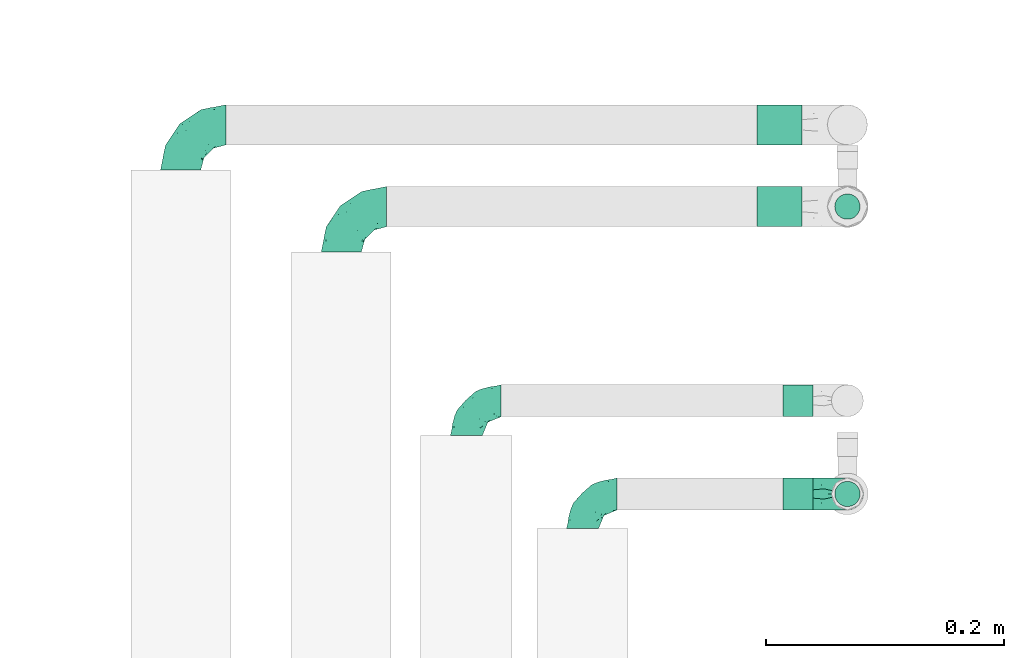
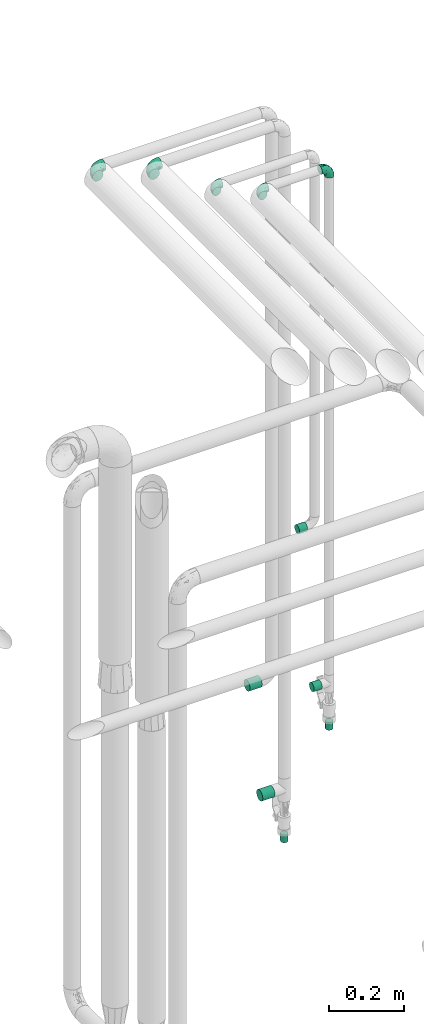
# One storey, part 746 of 827: 11 flow fittings.
"""IFC2X3 building model written with IfcOpenShell, lengths in millimetres."""

from ifc_helpers import new_model, entity, si_unit, converted_unit, derived_unit, direction, frame, origin, origin_2d_with_axis, place, context, subcontext, project, spatial, circle, extrude, faceted_brep, source, transform, mapped, material, type_object, type_shapes, element, save


model = new_model("IFC2X3")

# Units and contexts
model_context = context("Model", 3, precision=0.01, world=origin(), true_north=direction((6.12303176911189e-17, 1.0)))
body_context = subcontext(model_context, "Body", "Model", "MODEL_VIEW")
ifc_project = project(units=[si_unit("LENGTHUNIT", "METRE", prefix="MILLI"), si_unit("AREAUNIT", "SQUARE_METRE"), si_unit("VOLUMEUNIT", "CUBIC_METRE"), converted_unit("PLANEANGLEUNIT", "DEGREE", entity("IfcRatioMeasure", 0.0174532925199433), si_unit("PLANEANGLEUNIT", "RADIAN"), dimensions=[0, 0, 0, 0, 0, 0, 0]), si_unit("MASSUNIT", "GRAM", prefix="KILO"), derived_unit("MASSDENSITYUNIT", [(si_unit("MASSUNIT", "GRAM", prefix="KILO"), 1), (si_unit("LENGTHUNIT", "METRE"), -3)]), derived_unit("MOMENTOFINERTIAUNIT", [(si_unit("LENGTHUNIT", "METRE"), 4)]), si_unit("TIMEUNIT", "SECOND"), si_unit("FREQUENCYUNIT", "HERTZ"), si_unit("THERMODYNAMICTEMPERATUREUNIT", "DEGREE_CELSIUS"), derived_unit("THERMALTRANSMITTANCEUNIT", [(si_unit("MASSUNIT", "GRAM", prefix="KILO"), 1), (si_unit("THERMODYNAMICTEMPERATUREUNIT", "KELVIN"), -1), (si_unit("TIMEUNIT", "SECOND"), -3)]), derived_unit("VOLUMETRICFLOWRATEUNIT", [(si_unit("LENGTHUNIT", "METRE"), 3), (si_unit("TIMEUNIT", "SECOND"), -1)]), derived_unit("MASSFLOWRATEUNIT", [(si_unit("MASSUNIT", "GRAM", prefix="KILO"), 1), (si_unit("TIMEUNIT", "SECOND"), -1)]), derived_unit("ROTATIONALFREQUENCYUNIT", [(si_unit("TIMEUNIT", "SECOND"), -1)]), si_unit("ELECTRICCURRENTUNIT", "AMPERE"), si_unit("ELECTRICVOLTAGEUNIT", "VOLT"), si_unit("POWERUNIT", "WATT"), si_unit("FORCEUNIT", "NEWTON", prefix="KILO"), si_unit("ILLUMINANCEUNIT", "LUX"), si_unit("LUMINOUSFLUXUNIT", "LUMEN"), si_unit("LUMINOUSINTENSITYUNIT", "CANDELA"), derived_unit("USERDEFINED", [(si_unit("MASSUNIT", "GRAM", prefix="KILO"), -1), (si_unit("LENGTHUNIT", "METRE"), -2), (si_unit("TIMEUNIT", "SECOND"), 3), (si_unit("LUMINOUSFLUXUNIT", "LUMEN"), 1)]), derived_unit("LINEARVELOCITYUNIT", [(si_unit("LENGTHUNIT", "METRE"), 1), (si_unit("TIMEUNIT", "SECOND"), -1)]), si_unit("PRESSUREUNIT", "PASCAL"), derived_unit("USERDEFINED", [(si_unit("LENGTHUNIT", "METRE"), -2), (si_unit("MASSUNIT", "GRAM", prefix="KILO"), 1), (si_unit("TIMEUNIT", "SECOND"), -2)]), derived_unit("LINEARFORCEUNIT", [(si_unit("MASSUNIT", "GRAM", prefix="KILO"), 1), (si_unit("LENGTHUNIT", "METRE"), 1), (si_unit("TIMEUNIT", "SECOND"), -2), (si_unit("LENGTHUNIT", "METRE"), -1)]), derived_unit("PLANARFORCEUNIT", [(si_unit("MASSUNIT", "GRAM", prefix="KILO"), 1), (si_unit("LENGTHUNIT", "METRE"), 1), (si_unit("TIMEUNIT", "SECOND"), -2), (si_unit("LENGTHUNIT", "METRE"), -2)])], contexts=[model_context])

# Site, building, storey
site_placement = place(None, origin())
site = spatial("IfcSite", under=ifc_project, at=site_placement, CompositionType="ELEMENT")
building_placement = place(site_placement, origin())
building = spatial("IfcBuilding", under=site, at=building_placement, CompositionType="ELEMENT")
storey_placement = place(building_placement, frame((0.0, 0.0, 28200.0)))
storey = spatial("IfcBuildingStorey", under=building, at=storey_placement, Name="08", CompositionType="ELEMENT", Elevation=28200.0)

# Flow fittings
ifc_material = material()
pipe_fitting_type_1 = type_object("IfcPipeFittingType", PredefinedType="NOTDEFINED", material=ifc_material)
shared_shape_1 = source(origin(), body_context, "Body", "SweptSolid", [
    extrude(circle(Radius=16.85, at=origin_2d_with_axis()), frame((0.0, 0.0, 0.0), z_axis=(1.0, 0.0, 0.0), x_axis=(0.0, 1.0, 0.0)), (0.0, 0.0, 1.0), 38.0000000000003),
])
type_shapes(pipe_fitting_type_1, [shared_shape_1])
for number, where, z_axis, x_axis in (
    (1, (18867.55, 16586.6, 738.03), (0.0, 1.0, 0.0), (-1.0, 0.0, 0.0)),
    (2, (18867.55, 16517.91, 419.5), (0.0, 1.0, 0.0), (-1.0, 0.0, 0.0)),
):
    element("IfcFlowFitting", number, at=place(storey_placement, frame(where, z_axis=z_axis, x_axis=x_axis)), inside=storey, type_object=pipe_fitting_type_1, material=ifc_material, context=body_context, shape_type="MappedRepresentation", body=[
        mapped(shared_shape_1, transform((0.0, 0.0, 0.0), scale=1.0)),
    ])
pipe_fitting_type_2 = type_object("IfcPipeFittingType", PredefinedType="NOTDEFINED", material=ifc_material)
shared_shape_2 = source(origin(), body_context, "Body", "SweptSolid", [
    extrude(circle(Radius=10.65, at=origin_2d_with_axis()), frame((0.0, 0.0, 0.0), z_axis=(1.0, 0.0, 0.0), x_axis=(0.0, 1.0, 0.0)), (0.0, 0.0, 1.0), 25.0000000000003),
])
type_shapes(pipe_fitting_type_2, [shared_shape_2])
for number, where, z_axis, x_axis in (
    (3, (18905.55, 16517.91, 269.5), (0.0, 1.0, 0.0), (0.0, 0.0, -1.0)),
    (4, (18905.55, 16276.57, 784.61), (0.0, 1.0, 0.0), (0.0, 0.0, -1.0)),
):
    element("IfcFlowFitting", number, at=place(storey_placement, frame(where, z_axis=z_axis, x_axis=x_axis)), inside=storey, type_object=pipe_fitting_type_2, material=ifc_material, context=body_context, shape_type="MappedRepresentation", body=[
        mapped(shared_shape_2, transform((0.0, 0.0, 0.0), scale=1.0)),
    ])
pipe_fitting_type_3 = type_object("IfcPipeFittingType", PredefinedType="NOTDEFINED", material=ifc_material)
shared_shape_3 = source(origin(), body_context, "Body", "SweptSolid", [
    extrude(circle(Radius=13.45, at=origin_2d_with_axis()), frame((0.0, 0.0, 0.0), z_axis=(1.0, 0.0, 0.0), x_axis=(0.0, 1.0, 0.0)), (0.0, 0.0, 1.0), 25.0000000000003),
])
type_shapes(pipe_fitting_type_3, [shared_shape_3])
for number, where, z_axis, x_axis in (
    (5, (18876.45, 16354.91, 1382.4), (0.0, 1.0, 0.0), (-1.0, 0.0, 0.0)),
    (6, (18876.55, 16276.57, 912.61), (0.0, 1.0, 0.0), (-1.0, 0.0, 0.0)),
):
    element("IfcFlowFitting", number, at=place(storey_placement, frame(where, z_axis=z_axis, x_axis=x_axis)), inside=storey, type_object=pipe_fitting_type_3, material=ifc_material, context=body_context, shape_type="MappedRepresentation", body=[
        mapped(shared_shape_3, transform((0.0, 0.0, 0.0), scale=1.0)),
    ])
pipe_fitting_type_4 = type_object("IfcPipeFittingType", Name="ADSK_1", PredefinedType="NOTDEFINED", material=ifc_material)
shared_shape_4 = source(origin(), body_context, "Body", "Brep", [
    faceted_brep([(-38.0, 0.0, -16.85), (-38.0, -4.36, -16.28), (-38.0, -8.43, -14.59), (-38.0, -11.91, -11.91), (-38.0, -14.59, -8.43), (-38.0, -16.28, -4.36), (-38.0, -16.85, 0.0), (-38.0, -16.28, 4.36), (-38.0, -14.59, 8.42), (-38.0, -11.91, 11.91), (-38.0, -8.43, 14.59), (-38.0, -4.36, 16.28), (-38.0, 0.0, 16.85), (-38.0, 4.36, 16.28), (-38.0, 8.42, 14.59), (-38.0, 11.91, 11.91), (-38.0, 14.59, 8.42), (-38.0, 16.28, 4.36), (-38.0, 16.85, 0.0), (-38.0, 16.28, -4.36), (-38.0, 14.59, -8.43), (-38.0, 11.91, -11.91), (-38.0, 8.42, -14.59), (-38.0, 4.36, -16.28), (-4.36, 38.0, -16.28), (-8.42, 38.0, -14.59), (-11.91, 38.0, -11.91), (-14.59, 38.0, -8.43), (-16.28, 38.0, -4.36), (-16.85, 38.0, 0.0), (-16.28, 38.0, 4.36), (-14.59, 38.0, 8.42), (-11.91, 38.0, 11.91), (-8.42, 38.0, 14.59), (-4.36, 38.0, 16.28), (0.0, 38.0, 16.85), (4.36, 38.0, 16.28), (8.43, 38.0, 14.59), (11.91, 38.0, 11.91), (14.59, 38.0, 8.42), (16.28, 38.0, 4.36), (16.85, 38.0, 0.0), (16.28, 38.0, -4.36), (14.59, 38.0, -8.43), (11.91, 38.0, -11.91), (8.43, 38.0, -14.59), (4.36, 38.0, -16.28), (0.0, 38.0, -16.85), (-27.9, -12.9, 9.54), (-27.5, -14.76, 0.0), (-16.53, -9.86, 8.66), (-24.93, -9.38, 12.63), (-29.29, -2.05, 16.58), (-26.82, 2.86, 16.81), (-25.18, -14.43, 5.37), (-4.54, 4.54, 14.04), (-15.36, -3.29, 14.19), (-7.56, -2.74, 10.9), (-28.06, -6.15, 15.21), (9.38, 24.93, 12.63), (-4.71, -4.42, 5.51), (-14.62, -10.99, 4.34), (-8.11, -6.73, 0.0), (-19.46, 0.42, 16.39), (-29.52, 14.25, 10.97), (-26.45, 18.14, 7.62), (-32.84, 15.94, 6.96), (-23.39, 16.22, 12.05), (-11.89, 8.53, 16.79), (-5.59, 13.42, 16.64), (-6.64, 18.62, 16.81), (-32.37, 10.35, 13.72), (-6.4, 32.67, 15.76), (-2.55, 28.48, 16.8), (6.81, 15.56, 11.71), (3.29, 15.36, 14.19), (-29.89, 18.0, 3.79), (-29.34, 6.81, 15.88), (-10.26, 4.27, 15.87), (-2.97, 11.0, 15.66), (2.45, 6.84, 10.65), (-1.8, -0.14, 8.44), (5.0, 5.5, 5.57), (-17.68, 27.4, 7.52), (14.43, 25.18, 5.37), (12.9, 27.9, 9.54), (9.86, 16.53, 8.66), (6.15, 28.06, 15.21), (-17.01, -12.67, 0.0), (2.05, 29.29, 16.58), (14.76, 27.5, 0.0), (10.99, 14.62, 4.34), (12.67, 17.01, 0.0), (-15.84, -6.82, 11.83), (-7.71, 25.61, 16.01), (-22.69, 22.69, 4.1), (-19.68, 27.42, 0.0), (-27.42, 19.68, 0.0), (-18.11, 29.67, 3.72), (-10.87, 29.33, 13.9), (-20.83, 21.64, 8.95), (-18.54, 20.86, 11.76), (-14.08, 30.19, 10.92), (-13.69, 20.27, 14.88), (-20.85, 7.92, 16.51), (-19.04, 4.79, 16.85), (-19.82, 12.26, 15.55), (-19.27, 16.43, 13.96), (-10.72, 19.56, 16.07), (-0.42, 19.46, 16.39), (-25.32, 12.08, 14.15), (-9.04, -6.0, 8.28), (-13.94, 13.94, 16.38), (0.78, -0.78, 0.0), (6.73, 8.11, 0.0), (-9.04, -6.0, -8.28), (-15.9, -7.04, -11.65), (-7.56, -2.74, -10.9), (6.15, 28.06, -15.21), (3.29, 15.36, -14.19), (-0.42, 19.46, -16.39), (-30.19, 14.08, -10.92), (-29.33, 10.87, -13.9), (-25.61, 7.71, -16.01), (-32.67, 6.4, -15.76), (-29.67, 18.11, -3.72), (-18.14, 26.45, -7.62), (-22.69, 22.69, -4.1), (-18.0, 29.89, -3.79), (-25.18, -14.43, -5.37), (-14.62, -10.99, -4.34), (-20.27, 13.69, -14.88), (-15.36, -3.29, -14.19), (-14.25, 29.52, -10.97), (-15.94, 32.84, -6.96), (-24.93, -9.38, -12.63), (-27.9, -12.9, -9.54), (6.81, 15.56, -11.71), (9.38, 24.93, -12.63), (-7.92, 20.85, -16.51), (-4.79, 19.04, -16.85), (-8.53, 11.89, -16.79), (-29.29, -2.05, -16.58), (-13.42, 5.59, -16.64), (-4.27, 10.26, -15.87), (-11.0, 2.97, -15.66), (-16.53, -9.86, -8.66), (-28.48, 2.55, -16.8), (-18.62, 6.64, -16.81), (10.99, 14.62, -4.34), (14.43, 25.18, -5.37), (-12.26, 19.82, -15.55), (-16.43, 19.27, -13.96), (12.9, 27.9, -9.54), (-10.35, 32.37, -13.72), (-6.81, 29.34, -15.88), (2.05, 29.29, -16.58), (-2.86, 26.82, -16.81), (-27.4, 17.68, -7.52), (5.0, 5.5, -5.57), (-16.22, 23.39, -12.05), (-28.06, -6.15, -15.21), (9.86, 16.53, -8.66), (-20.86, 18.54, -11.76), (-21.64, 20.83, -8.95), (-19.56, 10.72, -16.07), (-19.46, 0.42, -16.39), (-12.08, 25.32, -14.15), (-4.54, 4.54, -14.04), (-13.94, 13.94, -16.38), (2.45, 6.84, -10.65), (-4.71, -4.42, -5.51), (-1.8, -0.14, -8.44)], [[[0, 1, 2, 3, 4, 5, 6, 7, 8, 9, 10, 11, 12, 13, 14, 15, 16, 17, 18, 19, 20, 21, 22, 23]], [[24, 25, 26, 27, 28, 29, 30, 31, 32, 33, 34, 35, 36, 37, 38, 39, 40, 41, 42, 43, 44, 45, 46, 47]], [[8, 48, 9]], [[7, 6, 49]], [[48, 50, 51]], [[12, 52, 53]], [[8, 54, 48]], [[7, 54, 8]], [[55, 56, 57]], [[51, 10, 9]], [[51, 58, 10]], [[59, 38, 37]], [[60, 61, 62]], [[58, 56, 63]], [[64, 65, 66]], [[67, 65, 64]], [[68, 69, 70]], [[14, 71, 15]], [[11, 52, 12]], [[34, 72, 73]], [[12, 53, 13]], [[15, 64, 16]], [[74, 59, 75]], [[18, 17, 76]], [[66, 17, 16]], [[77, 13, 53]], [[13, 77, 14]], [[69, 78, 79]], [[80, 81, 82]], [[31, 30, 83]], [[84, 85, 86]], [[59, 87, 75]], [[61, 54, 88]], [[35, 89, 36]], [[84, 40, 39]], [[35, 34, 73]], [[90, 40, 84]], [[39, 38, 85]], [[10, 58, 11]], [[85, 84, 39]], [[91, 84, 86]], [[84, 92, 90]], [[87, 37, 36]], [[93, 56, 51]], [[94, 70, 73]], [[95, 96, 97]], [[84, 91, 92]], [[96, 98, 29]], [[33, 32, 99]], [[76, 95, 97]], [[100, 101, 83]], [[102, 99, 32]], [[65, 95, 76]], [[103, 94, 99]], [[95, 98, 96]], [[72, 99, 94]], [[72, 34, 33]], [[101, 99, 102]], [[7, 49, 54]], [[87, 59, 37]], [[104, 105, 68]], [[106, 103, 107]], [[106, 77, 104]], [[32, 31, 102]], [[94, 103, 108]], [[94, 108, 70]], [[89, 73, 109]], [[71, 64, 15]], [[110, 107, 67]], [[50, 48, 54]], [[51, 9, 48]], [[56, 58, 51]], [[88, 54, 49]], [[52, 58, 63]], [[50, 111, 93]], [[56, 55, 78]], [[38, 59, 85]], [[86, 85, 59]], [[89, 87, 36]], [[41, 40, 90]], [[109, 79, 75]], [[109, 75, 87]], [[75, 55, 80]], [[104, 77, 53]], [[71, 77, 110]], [[31, 83, 102]], [[101, 102, 83]], [[99, 101, 103]], [[106, 107, 110]], [[68, 70, 112]], [[109, 73, 70]], [[68, 112, 104]], [[68, 63, 78]], [[57, 93, 111]], [[80, 55, 57]], [[61, 50, 54]], [[80, 82, 86]], [[81, 57, 111]], [[74, 86, 59]], [[60, 113, 82]], [[82, 114, 91]], [[100, 95, 65]], [[98, 95, 83]], [[73, 89, 35]], [[87, 89, 109]], [[58, 52, 11]], [[53, 52, 63]], [[104, 53, 105]], [[106, 104, 112]], [[18, 76, 97]], [[76, 17, 66]], [[103, 106, 112]], [[77, 106, 110]], [[103, 101, 107]], [[67, 107, 101]], [[67, 101, 100]], [[110, 67, 64]], [[83, 30, 98]], [[29, 98, 30]], [[53, 63, 105]], [[63, 68, 105]], [[56, 78, 63]], [[79, 78, 55]], [[75, 79, 55]], [[69, 79, 109]], [[70, 69, 109]], [[78, 69, 68]], [[62, 113, 60]], [[111, 61, 60]], [[61, 88, 62]], [[86, 82, 91]], [[77, 71, 14]], [[114, 82, 113]], [[114, 92, 91]], [[64, 71, 110]], [[99, 72, 33]], [[73, 72, 94]], [[64, 66, 16]], [[76, 66, 65]], [[95, 100, 83]], [[67, 100, 65]], [[75, 80, 74]], [[80, 86, 74]], [[103, 112, 108]], [[70, 108, 112]], [[50, 93, 51]], [[57, 56, 93]], [[61, 111, 50]], [[81, 111, 60]], [[82, 81, 60]], [[80, 57, 81]], [[115, 116, 117]], [[118, 119, 120]], [[121, 122, 21]], [[123, 124, 122]], [[97, 125, 18]], [[126, 127, 128]], [[127, 97, 96]], [[129, 130, 88]], [[123, 122, 131]], [[116, 132, 117]], [[133, 126, 134]], [[22, 124, 23]], [[3, 135, 136]], [[137, 119, 138]], [[129, 88, 49]], [[139, 140, 141]], [[4, 3, 136]], [[45, 118, 46]], [[142, 1, 0]], [[143, 144, 145]], [[4, 129, 5]], [[129, 136, 146]], [[147, 0, 23]], [[22, 21, 122]], [[127, 125, 97]], [[123, 148, 147]], [[96, 128, 127]], [[149, 150, 92]], [[29, 28, 128]], [[151, 131, 152]], [[26, 133, 27]], [[153, 44, 43]], [[135, 3, 2]], [[26, 25, 154]], [[155, 25, 24]], [[47, 156, 157]], [[47, 46, 156]], [[20, 19, 158]], [[159, 149, 114]], [[126, 133, 160]], [[141, 143, 148]], [[45, 138, 118]], [[161, 135, 2]], [[155, 24, 157]], [[23, 124, 147]], [[115, 146, 116]], [[44, 153, 138]], [[138, 45, 44]], [[153, 162, 138]], [[161, 2, 1]], [[41, 90, 42]], [[130, 129, 146]], [[49, 5, 129]], [[42, 150, 43]], [[163, 122, 121]], [[47, 157, 24]], [[135, 161, 132]], [[134, 28, 27]], [[42, 90, 150]], [[164, 163, 158]], [[151, 155, 139]], [[21, 20, 121]], [[123, 131, 165]], [[123, 165, 148]], [[142, 147, 166]], [[154, 133, 26]], [[167, 152, 160]], [[146, 136, 135]], [[6, 5, 49]], [[129, 4, 136]], [[142, 161, 1]], [[166, 145, 132]], [[166, 132, 161]], [[132, 168, 117]], [[43, 150, 153]], [[92, 150, 90]], [[162, 153, 150]], [[119, 118, 138]], [[156, 118, 120]], [[137, 138, 162]], [[119, 168, 144]], [[139, 155, 157]], [[154, 155, 167]], [[20, 158, 121]], [[163, 121, 158]], [[122, 163, 131]], [[151, 152, 167]], [[141, 148, 169]], [[166, 147, 148]], [[141, 169, 139]], [[141, 120, 144]], [[168, 170, 117]], [[159, 171, 172]], [[115, 172, 171]], [[171, 62, 130]], [[119, 170, 168]], [[170, 162, 159]], [[149, 162, 150]], [[113, 171, 159]], [[164, 127, 126]], [[125, 127, 158]], [[147, 142, 0]], [[161, 142, 166]], [[118, 156, 46]], [[157, 156, 120]], [[139, 157, 140]], [[151, 139, 169]], [[29, 128, 96]], [[128, 28, 134]], [[131, 151, 169]], [[155, 151, 167]], [[131, 163, 152]], [[160, 152, 163]], [[160, 163, 164]], [[167, 160, 133]], [[158, 19, 125]], [[18, 125, 19]], [[157, 120, 140]], [[120, 141, 140]], [[119, 144, 120]], [[145, 144, 168]], [[132, 145, 168]], [[143, 145, 166]], [[148, 143, 166]], [[144, 143, 141]], [[115, 130, 146]], [[114, 113, 159]], [[62, 171, 113]], [[62, 88, 130]], [[159, 162, 149]], [[149, 92, 114]], [[155, 154, 25]], [[133, 154, 167]], [[122, 124, 22]], [[147, 124, 123]], [[133, 134, 27]], [[128, 134, 126]], [[127, 164, 158]], [[160, 164, 126]], [[162, 170, 137]], [[170, 119, 137]], [[131, 169, 165]], [[148, 165, 169]], [[146, 135, 116]], [[132, 116, 135]], [[172, 115, 117]], [[130, 115, 171]], [[117, 170, 172]], [[159, 172, 170]]]),
])
type_shapes(pipe_fitting_type_4, [shared_shape_4])
for number, where, z_axis, x_axis, name in (
    (7, (18480.55, 16517.91, 2600.0), (0.0, 0.0, 1.0), (-1.0, 0.0, 0.0), "ADSK_1"),
    (8, (18345.55, 16586.6, 2600.0), (0.0, 0.0, 1.0), (-1.0, 0.0, 0.0), "ADSK_1"),
):
    element("IfcFlowFitting", number, at=place(storey_placement, frame(where, z_axis=z_axis, x_axis=x_axis)), inside=storey, type_object=pipe_fitting_type_4, material=ifc_material, Name=name, ObjectType="ADSK_1", context=body_context, shape_type="MappedRepresentation", body=[
        mapped(shared_shape_4, transform((0.0, 0.0, 0.0), scale=1.0)),
    ])
pipe_fitting_type_5 = type_object("IfcPipeFittingType", Name="ADSK_1", PredefinedType="NOTDEFINED", material=ifc_material)
shared_shape_5 = source(origin(), body_context, "Body", "Brep", [
    faceted_brep([(-29.1, 0.0, -13.45), (-29.1, -3.48, -12.99), (-29.1, -6.73, -11.65), (-29.1, -9.51, -9.51), (-29.1, -11.65, -6.73), (-29.1, -12.99, -3.48), (-29.1, -13.45, 0.0), (-29.1, -12.99, 3.48), (-29.1, -11.65, 6.72), (-29.1, -9.51, 9.51), (-29.1, -6.73, 11.65), (-29.1, -3.48, 12.99), (-29.1, 0.0, 13.45), (-29.1, 3.48, 12.99), (-29.1, 6.72, 11.65), (-29.1, 9.51, 9.51), (-29.1, 11.65, 6.72), (-29.1, 12.99, 3.48), (-29.1, 13.45, 0.0), (-29.1, 12.99, -3.48), (-29.1, 11.65, -6.73), (-29.1, 9.51, -9.51), (-29.1, 6.72, -11.65), (-29.1, 3.48, -12.99), (-3.48, 29.1, -12.99), (-6.72, 29.1, -11.65), (-9.51, 29.1, -9.51), (-11.65, 29.1, -6.73), (-12.99, 29.1, -3.48), (-13.45, 29.1, 0.0), (-12.99, 29.1, 3.48), (-11.65, 29.1, 6.72), (-9.51, 29.1, 9.51), (-6.72, 29.1, 11.65), (-3.48, 29.1, 12.99), (0.0, 29.1, 13.45), (3.48, 29.1, 12.99), (6.73, 29.1, 11.65), (9.51, 29.1, 9.51), (11.65, 29.1, 6.72), (12.99, 29.1, 3.48), (13.45, 29.1, 0.0), (12.99, 29.1, -3.48), (11.65, 29.1, -6.73), (9.51, 29.1, -9.51), (6.73, 29.1, -11.65), (3.48, 29.1, -12.99), (0.0, 29.1, -13.45), (-19.62, -11.66, 4.28), (-21.41, -10.36, 7.6), (-16.26, -10.01, 0.0), (-12.48, -9.76, 2.75), (-10.66, 15.6, 11.91), (-15.27, 9.55, 12.42), (-10.71, 10.71, 13.09), (-0.04, 0.04, 0.0), (0.49, -0.45, 4.38), (-3.67, -4.15, 4.26), (-22.68, -11.73, 0.0), (-21.45, -4.97, 12.13), (-11.59, -2.84, 11.28), (-14.77, 0.17, 13.07), (-19.08, -7.58, 10.06), (-22.36, -1.69, 13.23), (-20.49, 2.21, 13.42), (-7.82, -7.75, 0.0), (-5.53, -2.55, 8.58), (-1.33, -0.87, 6.53), (-1.15, 1.15, 8.49), (-22.46, 5.38, 12.69), (-14.04, 21.05, 6.04), (-3.19, 3.19, 11.14), (-5.08, 25.05, 12.59), (-1.97, 21.79, 13.41), (-22.68, 11.31, 8.78), (-18.16, 12.64, 9.68), (-20.46, 14.33, 6.11), (-4.13, 10.11, 13.26), (-7.66, 3.08, 12.63), (-2.02, 8.24, 12.45), (-24.91, 8.22, 10.95), (-5.08, 14.28, 13.42), (-8.96, 6.48, 13.4), (-19.7, 16.14, 3.1), (-18.03, 18.03, 0.0), (-23.05, 15.96, 0.0), (-25.26, 12.69, 5.56), (4.97, 21.45, 12.13), (7.58, 19.08, 10.06), (1.69, 22.36, 13.23), (10.36, 21.41, 7.6), (8.11, 12.69, 6.86), (11.66, 19.62, 4.28), (-6.03, 19.65, 12.79), (9.76, 12.48, 2.75), (10.01, 16.26, 0.0), (-14.58, 16.06, 9.44), (-11.19, 23.14, 8.74), (-16.29, 16.8, 7.24), (-11.99, -5.68, 9.36), (-15.42, 20.78, 3.08), (5.79, 12.02, 9.27), (2.84, 11.59, 11.28), (2.55, 5.53, 8.58), (-15.74, 23.57, 0.0), (-15.96, 23.05, 0.0), (-24.62, 13.88, 2.39), (-8.61, 22.49, 11.12), (-14.98, 12.8, 11.14), (11.73, 22.68, 0.0), (-12.69, -8.11, 6.86), (7.75, 7.82, 0.0), (-15.98, 6.12, 13.19), (-14.48, 3.64, 13.45), (-19.6, 9.46, 11.31), (-8.3, 15.02, 12.85), (-0.17, 14.77, 13.07), (-6.9, -5.2, 6.52), (7.5, 8.93, 4.46), (5.22, 6.95, 6.56), (-8.85, -7.47, 4.42), (3.86, 3.93, 0.0), (4.18, 3.75, 4.31), (-23.57, 15.74, 0.0), (-3.93, -3.86, 0.0), (-21.79, 1.97, -13.41), (-11.31, 22.68, -8.78), (-14.33, 20.46, -6.11), (-12.69, 25.26, -5.56), (4.97, 21.45, -12.13), (2.84, 11.59, -11.28), (-0.17, 14.77, -13.07), (-25.05, 5.08, -12.59), (-16.8, 16.29, -7.24), (-20.78, 15.42, -3.08), (-16.14, 19.7, -3.1), (-12.02, -5.79, -9.27), (-11.59, -2.84, -11.28), (-5.53, -2.55, -8.58), (-23.14, 11.19, -8.74), (-22.49, 8.61, -11.12), (-1.33, -0.87, -6.53), (-3.67, -4.15, -4.26), (-6.9, -5.2, -6.52), (-19.65, 6.03, -12.79), (-15.6, 10.66, -11.91), (-14.28, 5.08, -13.42), (-10.71, 10.71, -13.09), (-6.48, 8.96, -13.4), (-19.62, -11.66, -4.28), (-21.41, -10.36, -7.6), (-12.48, -9.76, -2.75), (11.66, 19.62, -4.28), (-12.69, -8.11, -6.86), (-22.36, -1.69, -13.23), (-16.06, 14.58, -9.44), (5.68, 11.99, -9.36), (7.58, 19.08, -10.06), (-19.08, -7.58, -10.06), (-21.45, -4.97, -12.13), (-9.55, 15.27, -12.42), (-12.8, 14.98, -11.14), (-8.22, 24.91, -10.95), (10.36, 21.41, -7.6), (-5.38, 22.46, -12.69), (1.69, 22.36, -13.23), (-2.21, 20.49, -13.42), (-12.64, 18.16, -9.68), (-21.05, 14.04, -6.04), (9.76, 12.48, -2.75), (-10.11, 4.13, -13.26), (-3.08, 7.66, -12.63), (-8.24, 2.02, -12.45), (-13.88, 24.62, -2.39), (8.11, 12.69, -6.86), (-6.12, 15.98, -13.19), (-3.64, 14.48, -13.45), (-9.46, 19.6, -11.31), (-15.02, 8.3, -12.85), (-14.77, 0.17, -13.07), (-3.19, 3.19, -11.14), (5.22, 6.95, -6.56), (2.55, 5.53, -8.58), (0.49, -0.45, -4.38), (4.18, 3.75, -4.31), (-8.85, -7.47, -4.42), (-1.15, 1.15, -8.49), (7.5, 8.93, -4.46)], [[[0, 1, 2, 3, 4, 5, 6, 7, 8, 9, 10, 11, 12, 13, 14, 15, 16, 17, 18, 19, 20, 21, 22, 23]], [[24, 25, 26, 27, 28, 29, 30, 31, 32, 33, 34, 35, 36, 37, 38, 39, 40, 41, 42, 43, 44, 45, 46, 47]], [[48, 49, 8]], [[48, 50, 51]], [[52, 53, 54]], [[55, 56, 57]], [[49, 9, 8]], [[58, 48, 7]], [[59, 60, 61]], [[62, 10, 9]], [[62, 59, 10]], [[12, 63, 64]], [[51, 50, 65]], [[66, 67, 68]], [[12, 11, 63]], [[69, 14, 13]], [[31, 30, 70]], [[66, 71, 60]], [[34, 72, 73]], [[74, 75, 76]], [[77, 78, 79]], [[14, 80, 15]], [[16, 15, 74]], [[81, 54, 82]], [[83, 84, 85]], [[74, 76, 86]], [[37, 87, 88]], [[88, 38, 37]], [[36, 35, 89]], [[90, 91, 92]], [[93, 81, 73]], [[35, 34, 73]], [[10, 59, 11]], [[92, 94, 95]], [[96, 97, 98]], [[90, 92, 39]], [[99, 60, 62]], [[40, 39, 92]], [[87, 37, 36]], [[100, 84, 83]], [[50, 48, 58]], [[100, 83, 98]], [[101, 102, 103]], [[104, 105, 84, 100, 29]], [[48, 8, 7]], [[86, 17, 16]], [[106, 18, 17]], [[32, 97, 107]], [[53, 52, 108]], [[52, 93, 107]], [[97, 96, 107]], [[72, 107, 93]], [[72, 34, 33]], [[92, 109, 40]], [[33, 32, 107]], [[69, 13, 64]], [[88, 87, 102]], [[12, 64, 13]], [[49, 110, 62]], [[39, 38, 90]], [[95, 94, 111]], [[112, 113, 82]], [[53, 69, 112]], [[80, 74, 15]], [[114, 108, 75]], [[32, 31, 97]], [[115, 52, 54]], [[93, 115, 81]], [[89, 73, 116]], [[106, 76, 83]], [[106, 83, 85]], [[83, 76, 98]], [[100, 30, 29]], [[60, 59, 62]], [[63, 59, 61]], [[110, 117, 99]], [[60, 71, 78]], [[89, 87, 36]], [[116, 79, 102]], [[116, 102, 87]], [[102, 71, 103]], [[110, 49, 48]], [[62, 9, 49]], [[38, 88, 90]], [[91, 90, 88]], [[112, 69, 64]], [[80, 69, 114]], [[111, 94, 118]], [[119, 101, 103]], [[117, 66, 99]], [[117, 120, 57]], [[119, 91, 101]], [[66, 68, 71]], [[66, 117, 67]], [[121, 111, 122, 55]], [[56, 55, 122]], [[31, 70, 97]], [[97, 70, 98]], [[107, 96, 52]], [[53, 108, 114]], [[112, 82, 54]], [[116, 73, 81]], [[78, 82, 61]], [[81, 82, 77]], [[73, 89, 35]], [[87, 89, 116]], [[59, 63, 11]], [[64, 63, 61]], [[112, 64, 113]], [[53, 112, 54]], [[7, 6, 58]], [[109, 92, 95]], [[109, 41, 40]], [[69, 53, 114]], [[52, 96, 108]], [[75, 108, 96]], [[75, 96, 98]], [[114, 75, 74]], [[64, 61, 113]], [[61, 82, 113]], [[91, 88, 101]], [[110, 48, 51]], [[92, 91, 94]], [[91, 119, 118]], [[106, 85, 123, 18]], [[106, 17, 86]], [[60, 78, 61]], [[79, 78, 71]], [[102, 79, 71]], [[77, 79, 116]], [[81, 77, 116]], [[78, 77, 82]], [[69, 80, 14]], [[74, 80, 114]], [[74, 86, 16]], [[106, 86, 76]], [[107, 72, 33]], [[73, 72, 93]], [[98, 70, 100]], [[75, 98, 76]], [[30, 100, 70]], [[110, 99, 62]], [[66, 60, 99]], [[120, 110, 51]], [[67, 117, 57]], [[57, 56, 67]], [[67, 122, 119]], [[110, 120, 117]], [[65, 120, 51]], [[57, 65, 124, 55]], [[122, 67, 56]], [[67, 103, 68]], [[71, 68, 103]], [[65, 57, 120]], [[102, 101, 88]], [[67, 119, 103]], [[118, 119, 122]], [[118, 122, 111]], [[91, 118, 94]], [[81, 115, 54]], [[93, 52, 115]], [[23, 125, 0]], [[126, 127, 128]], [[129, 130, 131]], [[23, 22, 132]], [[133, 134, 135]], [[136, 137, 138]], [[21, 139, 140]], [[141, 142, 143]], [[144, 140, 145]], [[143, 136, 138]], [[146, 147, 148]], [[144, 132, 140]], [[5, 4, 149]], [[4, 3, 150]], [[45, 129, 46]], [[151, 50, 149]], [[152, 43, 42]], [[42, 41, 109]], [[150, 149, 4]], [[153, 149, 150]], [[154, 1, 0]], [[139, 155, 140]], [[156, 130, 157]], [[149, 58, 5]], [[18, 123, 85, 84, 134]], [[158, 159, 137]], [[84, 105, 135]], [[160, 145, 161]], [[143, 153, 136]], [[27, 26, 126]], [[25, 162, 26]], [[152, 163, 43]], [[25, 24, 164]], [[47, 165, 166]], [[158, 3, 2]], [[167, 127, 126]], [[20, 19, 168]], [[47, 46, 165]], [[44, 157, 45]], [[23, 132, 125]], [[44, 43, 163]], [[158, 2, 159]], [[47, 166, 24]], [[129, 45, 157]], [[164, 24, 166]], [[134, 84, 135]], [[95, 169, 152]], [[22, 21, 140]], [[144, 146, 125]], [[109, 152, 42]], [[95, 152, 109]], [[170, 171, 172]], [[155, 139, 133]], [[28, 27, 128]], [[159, 2, 1]], [[173, 29, 28]], [[50, 151, 65]], [[169, 95, 111]], [[163, 174, 157]], [[175, 176, 148]], [[160, 164, 175]], [[162, 126, 26]], [[177, 161, 167]], [[21, 20, 139]], [[144, 145, 178]], [[144, 178, 146]], [[154, 125, 179]], [[173, 127, 135]], [[173, 135, 105]], [[135, 127, 133]], [[134, 19, 18]], [[154, 159, 1]], [[179, 172, 137]], [[179, 137, 159]], [[137, 180, 138]], [[130, 129, 157]], [[165, 129, 131]], [[174, 181, 156]], [[130, 180, 171]], [[3, 158, 150]], [[153, 150, 158]], [[174, 163, 152]], [[157, 44, 163]], [[175, 164, 166]], [[162, 164, 177]], [[130, 182, 180]], [[181, 141, 182]], [[55, 183, 184]], [[65, 151, 185]], [[183, 55, 142]], [[156, 181, 182]], [[180, 182, 186]], [[181, 187, 184]], [[65, 142, 55, 124]], [[20, 168, 139]], [[139, 168, 133]], [[140, 155, 145]], [[160, 161, 177]], [[175, 148, 147]], [[179, 125, 146]], [[171, 148, 131]], [[146, 148, 170]], [[125, 154, 0]], [[159, 154, 179]], [[129, 165, 46]], [[166, 165, 131]], [[175, 166, 176]], [[160, 175, 147]], [[58, 149, 50]], [[58, 6, 5]], [[145, 160, 147]], [[164, 160, 177]], [[145, 155, 161]], [[167, 161, 155]], [[167, 155, 133]], [[177, 167, 126]], [[166, 131, 176]], [[131, 148, 176]], [[149, 153, 151]], [[153, 143, 185]], [[145, 147, 178]], [[174, 152, 169]], [[173, 105, 104, 29]], [[173, 28, 128]], [[130, 171, 131]], [[172, 171, 180]], [[137, 172, 180]], [[170, 172, 179]], [[146, 170, 179]], [[171, 170, 148]], [[164, 162, 25]], [[126, 162, 177]], [[126, 128, 27]], [[173, 128, 127]], [[140, 132, 22]], [[125, 132, 144]], [[133, 168, 134]], [[167, 133, 127]], [[19, 134, 168]], [[153, 158, 136]], [[137, 136, 158]], [[141, 143, 138]], [[185, 143, 142]], [[186, 141, 138]], [[183, 142, 141]], [[185, 142, 65]], [[153, 185, 151]], [[180, 186, 138]], [[182, 141, 186]], [[141, 184, 183]], [[184, 111, 121, 55]], [[174, 156, 157]], [[182, 130, 156]], [[187, 174, 169]], [[141, 181, 184]], [[174, 187, 181]], [[111, 187, 169]], [[111, 184, 187]], [[146, 178, 147]]]),
])
type_shapes(pipe_fitting_type_5, [shared_shape_5])
for number, where, z_axis, x_axis, name in (
    (9, (18683.05, 16276.57, 2600.0), (0.0, 0.0, 1.0), (-1.0, 0.0, 0.0), "ADSK_1"),
    (10, (18905.55, 16276.57, 2600.0), (0.0, 1.0, 0.0), (1.0, 0.0, 0.0), "ADSK_1"),
    (11, (18585.55, 16354.91, 2600.0), (0.0, 0.0, 1.0), (-1.0, 0.0, 0.0), "ADSK_1"),
):
    element("IfcFlowFitting", number, at=place(storey_placement, frame(where, z_axis=z_axis, x_axis=x_axis)), inside=storey, type_object=pipe_fitting_type_5, material=ifc_material, Name=name, ObjectType="ADSK_1", context=body_context, shape_type="MappedRepresentation", body=[
        mapped(shared_shape_5, transform((0.0, 0.0, 0.0), scale=1.0)),
    ])

save(model, "model.ifc")
